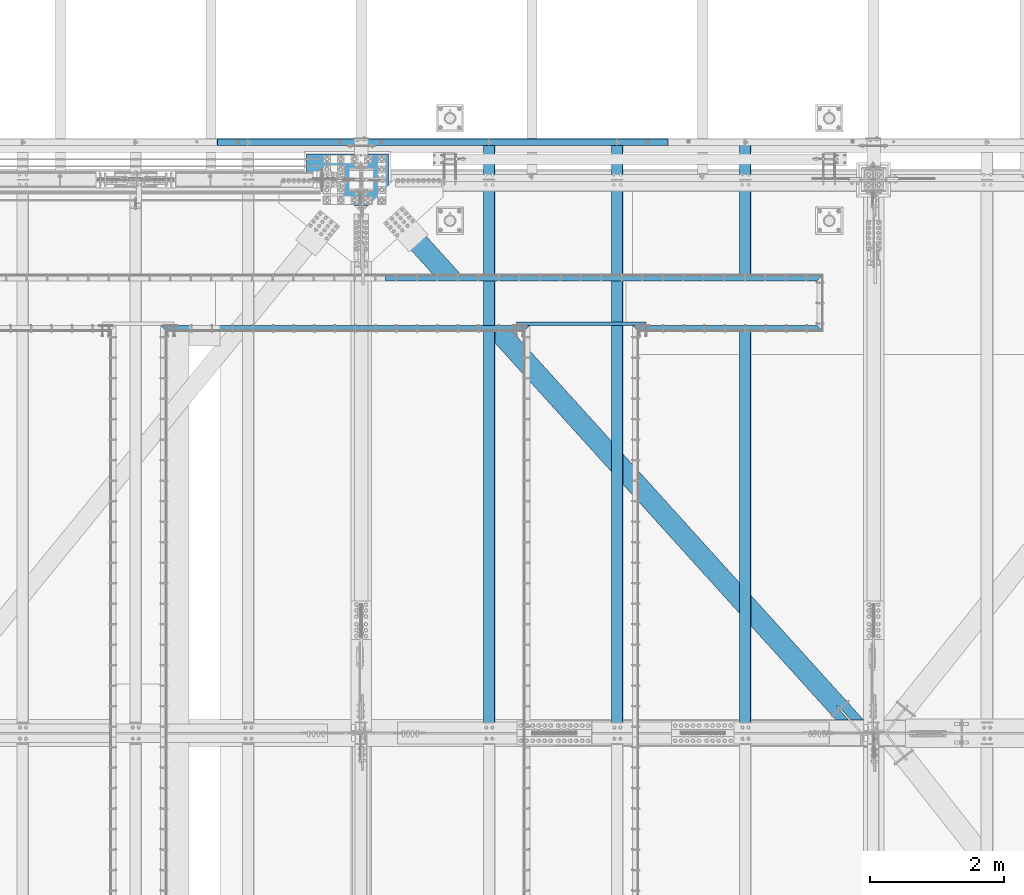
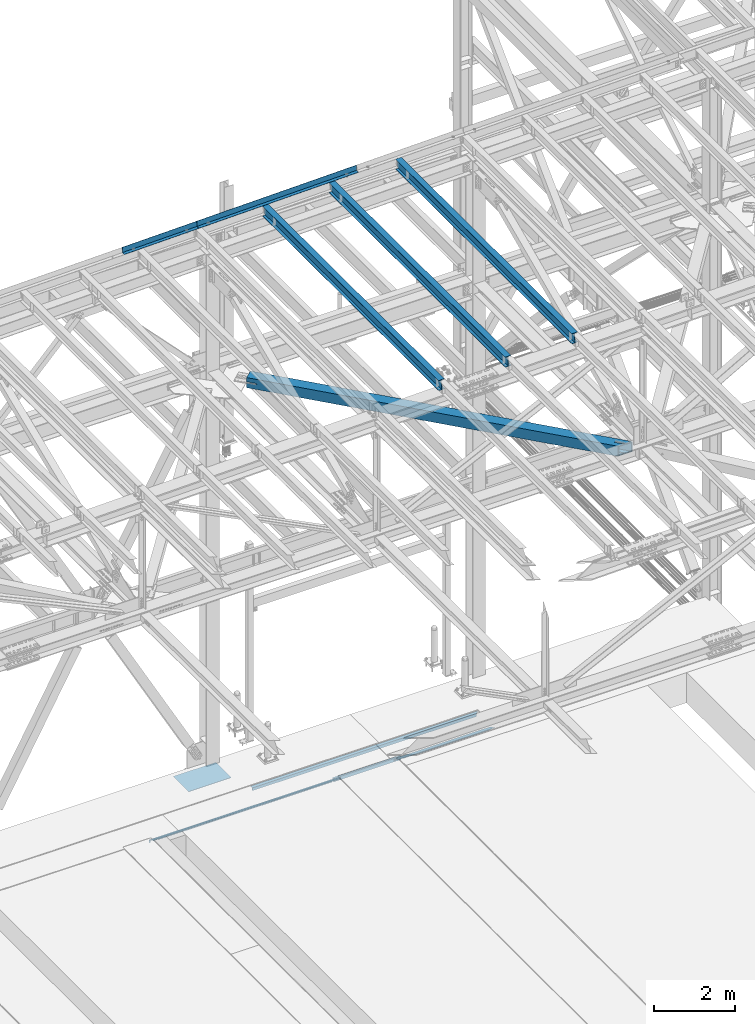
# One storey, part 1927 of 3843: 11 beams, 11 elements without a shape of their own.
"""IFC2X3 building model written with IfcOpenShell, lengths in millimetres."""

from ifc_helpers import new_model, si_unit, frame, origin_with_axes, place, context, subcontext, project, spatial, faceted_brep, material, type_object, element, aggregate, save


model = new_model("IFC2X3")

# Units and contexts
model_context = context("Model", 3, precision=1e-05, world=origin_with_axes())
body_context = subcontext(model_context, "Body", "Model", "MODEL_VIEW")
ifc_project = project(units=[si_unit("LENGTHUNIT", "METRE", prefix="MILLI"), si_unit("AREAUNIT", "SQUARE_METRE"), si_unit("VOLUMEUNIT", "CUBIC_METRE"), si_unit("MASSUNIT", "GRAM", prefix="KILO"), si_unit("TIMEUNIT", "SECOND"), si_unit("PLANEANGLEUNIT", "RADIAN"), si_unit("SOLIDANGLEUNIT", "STERADIAN"), si_unit("THERMODYNAMICTEMPERATUREUNIT", "DEGREE_CELSIUS"), si_unit("LUMINOUSINTENSITYUNIT", "LUMEN")], contexts=[model_context])

# Site, building, storey
site_placement = place(None, origin_with_axes())
site = spatial("IfcSite", under=ifc_project, at=site_placement, CompositionType="ELEMENT")
building_placement = place(site_placement, origin_with_axes())
building = spatial("IfcBuilding", under=site, at=building_placement, Name="Undefined", CompositionType="ELEMENT")
storey_placement = place(building_placement, origin_with_axes())
storey = spatial("IfcBuildingStorey", under=building, at=storey_placement, Name="Undefined", CompositionType="ELEMENT", Elevation=0.0)

# Assembly, beam
assembly_1_placement = place(storey_placement, origin_with_axes())
assembly_1 = element("IfcElementAssembly", 1, at=assembly_1_placement, inside=storey, Name="EMBED_ANGLE", AssemblyPlace="NOTDEFINED", PredefinedType="RIGID_FRAME")
ifc_material_1 = material(Name="STEEL/A36")
beam_type_1 = type_object("IfcBeamType", Name="L3-1/2X3-1/2X5/16", PredefinedType="NOTDEFINED")
beam_1_placement = place(assembly_1_placement, frame((66669.4120093833, 90004.7724002759, 30410.15), z_axis=(0.0, -1.0, 0.0), x_axis=(1.0, 0.0, 0.0)))
beam_1 = element("IfcBeam", 2, at=beam_1_placement, type_object=beam_type_1, material=ifc_material_1, Name="EMBED_ANGLE", ObjectType="L3-1/2X3-1/2X5/16", context=body_context, shape_type="Brep", body=[
    faceted_brep([(44.4499983150599, -44.4500000000007, -36.5125000001281), (44.4499999898835, -44.4500000000007, -44.4500000001281), (44.4499999898835, 36.5125000000044, -44.4500000001281), (44.4499983150599, 36.5125000000007, -36.5125000001281), (260.349999989907, 36.5125000000044, -44.4500000007247), (260.349998315098, 36.5125000000007, -36.5125000007247), (260.349998315098, -44.4499999999971, -36.5125000007247), (260.349999989907, -44.4500000000007, -44.4500000007247), (2743.19996850427, -44.4500000000007, -44.4500000076223), (2751.13746728744, -44.4500000000007, -36.5125000076368), (3.63797880709171e-12, -44.4499999999971, -44.4500000000007), (-3.63797880709171e-12, 44.4499999999971, -44.4500000000007), (2743.19996850427, 44.4500000000007, -44.4500000076223), (7.93749960740388, -44.4500000000007, -36.5124999999825), (7.93749960740388, 36.5125000000007, -36.5124999999825), (44.4499906109268, 36.5125000000007, -2.28901626542211e-08), (88.8999958229251, 36.5125000000007, 44.4500000001353), (88.8999999965163, 44.4499999999971, 44.4500000000007), (260.349981232008, 36.5125000000007, 44.4499999992695), (2832.09995487571, 36.5125000000007, 44.4499999921391), (2832.09995487571, 44.4500000000007, 44.4499999921391), (2751.13746728744, 36.5125000000007, -36.5125000076368)], [[[0, 1, 2, 3]], [[3, 2, 4, 5]], [[6, 5, 4, 7]], [[8, 9, 6, 7]], [[2, 1, 10, 11, 12, 8, 7, 4]], [[13, 10, 1, 0]], [[14, 13, 0, 3]], [[10, 13, 14, 15, 16, 17, 11]], [[17, 16, 18, 19, 20]], [[11, 17, 20, 12]], [[19, 21, 9, 8, 12, 20]], [[18, 16, 15, 14, 3, 5, 21, 19]], [[9, 21, 5, 6]]]),
])
aggregate(assembly_1, [beam_1])

assembly_2_placement = place(storey_placement, origin_with_axes())
assembly_2 = element("IfcElementAssembly", 3, at=assembly_2_placement, inside=storey, Name="EMBED_ANGLE", AssemblyPlace="NOTDEFINED", PredefinedType="RIGID_FRAME")
beam_2_placement = place(assembly_2_placement, frame((59652.6620031643, 90004.7723125, 30410.15), z_axis=(0.0, -1.0, 0.0), x_axis=(1.0, 0.0, 0.0)))
beam_2 = element("IfcBeam", 4, at=beam_2_placement, type_object=beam_type_1, material=ifc_material_1, Name="EMBED_ANGLE", ObjectType="L3-1/2X3-1/2X5/16", context=body_context, shape_type="Brep", body=[
    faceted_brep([(44.4499983150599, -44.4500000000007, -36.5125000001281), (44.4499999898835, -44.4500000000007, -44.4500000001281), (44.4499999898835, 36.5125000000044, -44.4500000001281), (44.4499983150599, 36.5125000000007, -36.5125000001281), (260.349999989907, 36.5125000000044, -44.4500000007247), (260.349998315098, 36.5125000000007, -36.5125000007247), (260.349998315098, -44.4499999999971, -36.5125000007247), (260.349999989907, -44.4500000000007, -44.4500000007247), (5492.75009508596, -44.4500000000007, -44.4499999933905), (5484.81267681251, -44.4500000000007, -36.5124999933905), (5448.32660764583, -44.4499999999971, -36.5124999934487), (5448.32660820939, -44.4500000000007, -44.4499999934487), (5484.81267681251, 36.5125000000007, -36.5124999933905), (5448.32660764583, 36.5125000000007, -36.5124999934487), (5448.32660820939, 36.5125000000044, -44.4499999934487), (5232.42660764582, 36.5125000000007, -36.5124999937107), (5232.42660820938, 36.5125000000044, -44.4499999937107), (5232.42660764582, -44.4500000000007, -36.5124999937107), (5232.42660820938, -44.4500000000007, -44.4499999937107), (3.63797880709171e-12, -44.4499999999971, -44.4500000000007), (-3.63797880709171e-12, 44.4499999999971, -44.4500000000007), (5492.75009508596, 44.4500000000007, -44.4499999933905), (7.93749960740388, -44.4500000000007, -36.5124999999825), (7.93749960740388, 36.5125000000007, -36.5124999999825), (44.4499906109268, 36.5125000000007, -2.28901626542211e-08), (88.8999958229251, 36.5125000000007, 44.4500000001353), (88.8999999965163, 44.4499999999971, 44.4500000000007), (260.349981232008, 36.5125000000007, 44.4499999992695), (5232.42660189748, 36.5125000000007, 44.4500000062981), (5403.85101042334, 36.5125000000007, 44.4500000065018), (5403.85101042334, 44.4500000000007, 44.4500000065018), (5448.32660505529, 36.5125000000007, -0.0260525623307331)], [[[0, 1, 2, 3]], [[3, 2, 4, 5]], [[6, 5, 4, 7]], [[8, 9, 10, 11]], [[9, 12, 13, 10]], [[10, 13, 14, 11]], [[15, 16, 14, 13]], [[17, 18, 16, 15]], [[18, 17, 6, 7]], [[2, 1, 19, 20, 21, 8, 11, 14, 16, 18, 7, 4]], [[22, 19, 1, 0]], [[23, 22, 0, 3]], [[19, 22, 23, 24, 25, 26, 20]], [[26, 25, 27, 28, 29, 30]], [[20, 26, 30, 21]], [[29, 31, 12, 9, 8, 21, 30]], [[28, 27, 25, 24, 23, 3, 5, 15, 13, 12, 31, 29]], [[17, 15, 5, 6]]]),
])
aggregate(assembly_2, [beam_2])

assembly_3_placement = place(storey_placement, origin_with_axes())
assembly_3 = element("IfcElementAssembly", 5, at=assembly_3_placement, inside=storey, Name="EMBED_ANGLE", AssemblyPlace="NOTDEFINED", PredefinedType="RIGID_FRAME")
beam_3_placement = place(assembly_3_placement, frame((62999.1121552795, 90754.0730224609, 30410.15), z_axis=(0.0, 0.0, -1.0), x_axis=(1.0, 0.0, 0.0)))
beam_3 = element("IfcBeam", 6, at=beam_3_placement, type_object=beam_type_1, material=ifc_material_1, Name="EMBED_ANGLE", ObjectType="L3-1/2X3-1/2X5/16", context=body_context, shape_type="Brep", body=[
    faceted_brep([(-3.63797880709171e-12, 44.4499999999971, -44.4500000000007), (-3.63797880709171e-12, 44.4499999999971, 44.4500000000007), (6413.49979789655, 44.4499999999971, 44.4500000000007), (6413.49979789655, 44.4499999999971, -44.4500000000007), (-3.63797880709171e-12, 36.5124999999971, 44.4500000000007), (6421.43729768327, 36.5124999999971, 44.4500000000007), (-3.63797880709171e-12, 36.5124999999971, -36.5125000000007), (6421.43729768327, 36.5124999999971, -36.5125000000007), (3.63797880709171e-12, -44.4499999999971, -36.5125000000007), (6502.39979550779, -44.4499999999971, -36.5125000000007), (3.63797880709171e-12, -44.4499999999971, -44.4500000000007), (6502.39979550779, -44.4499999999971, -44.4500000000007)], [[[0, 1, 2, 3]], [[1, 4, 5, 2]], [[4, 6, 7, 5]], [[6, 8, 9, 7]], [[8, 10, 11, 9]], [[10, 0, 3, 11]], [[5, 7, 9, 11, 3, 2]], [[10, 8, 6, 4, 1, 0]]]),
])
aggregate(assembly_3, [beam_3])

assembly_4_placement = place(storey_placement, origin_with_axes())
assembly_4 = element("IfcElementAssembly", 7, at=assembly_4_placement, inside=storey, Name="BEAM", AssemblyPlace="NOTDEFINED", PredefinedType="RIGID_FRAME")
ifc_material_2 = material(Name="STEEL/A992")
beam_type_2 = type_object("IfcBeamType", Name="W12X26", PredefinedType="NOTDEFINED")
beam_4_placement = place(assembly_4_placement, frame((68348.1092623529, 83985.3697741057, 46261.5127701708), z_axis=(-0.0211520978230692, 0.00173404499923344, 0.999774765557535), x_axis=(0.0, 0.999998495869954, -0.00173443299977423)))
beam_4 = element("IfcBeam", 8, at=beam_4_placement, type_object=beam_type_2, material=ifc_material_2, Name="BEAM", ObjectType="W12X26", context=body_context, shape_type="Brep", body=[
    faceted_brep([(8748.72879077496, -3.17500000096334, -146.049999976822), (8748.72879077496, -82.5500000013853, -146.049999976771), (8748.72879077494, -82.5500000014144, -155.574999976721), (8748.72879077494, 82.549999999479, -155.574999976867), (8748.72879077497, 82.549999999479, -146.049999976894), (8748.72879077496, 3.17499999907159, -146.049999976829), (8748.72879077593, 3.17499999908614, -142.874999284111), (8748.72879077587, -3.17500000094878, -142.874999284119), (8749.69552069856, 3.17499999908614, -138.014919766138), (8749.6955206985, -3.17500000094878, -138.014919766145), (8752.44853459905, 3.17499999910069, -133.894743298035), (8752.448534599, -3.17500000093423, -133.894743298042), (8756.5687110672, 3.17499999911524, -131.141729397561), (8756.56871106714, -3.17500000093423, -131.141729397576), (8761.42879058523, 3.1749999991298, -130.174999474941), (8761.42879058517, -3.17500000091968, -130.174999474948), (8818.5316008915, -3.17500000090513, -130.174999473988), (8818.53183385366, 3.1749999991298, -130.174999474009), (12.1771034262492, 3.17500000049768, 146.049999999559), (12.1800154534576, 82.5500000009197, 146.049999999494), (8748.72879077714, 82.5500000004395, 146.050000022136), (8748.72879077712, 3.17500000001746, 146.050000022202), (12.6969905314618, -82.5500000009342, -155.574999999379), (12.6804737284838, -82.5500000009051, -146.049999999406), (12.6833857556921, -3.17500000048312, -146.049999999472), (12.1768704640854, -3.17499999953725, 146.049999999566), (12.1739584368624, -82.5499999999593, 146.049999999625), (12.1574416338699, -82.5499999999156, 155.57499999959), (12.1634986504796, 82.5500000009488, 155.574999999459), (12.6836187178706, 3.1749999995518, -146.049999999472), (12.6865307450789, 82.5499999999738, -146.049999999545), (12.7030475480569, 82.5499999999447, -155.57499999951), (8748.72879077714, -3.17500000000291, 146.050000022209), (8748.72879077712, -82.5500000004395, 146.050000022275), (8748.72879077714, -82.5500000004104, 155.575000022232), (8748.72879077715, 82.5500000004831, 155.575000022109), (8748.72879077778, -3.17500000001746, 142.875000331573), (8748.72879077785, 3.17500000001746, 142.875000331573), (8749.69552070032, -3.17500000004657, 138.014920813541), (8749.69552070039, 3.17500000000291, 138.014920813555), (8752.4485346008, -3.17500000004657, 133.894744345431), (8752.44853460087, 3.17499999998836, 133.894744345431), (8756.56871106898, -3.17500000006112, 131.141730444993), (8756.56871106903, 3.17499999997381, 131.141730445001), (8761.42879058704, -3.17500000006112, 130.17500052246), (8761.4287905871, 3.17499999995925, 130.175000522468), (8818.08014160984, -3.17500000007567, 130.175000522169), (8818.080374572, 3.17499999995925, 130.175000522147), (8818.50217237184, 3.17499999917345, -113.06965441037), (8818.1023016062, 3.17499999993015, 117.529998893144)], [[[0, 1, 2, 3, 4, 5, 6, 7]], [[7, 6, 8, 9]], [[9, 8, 10, 11]], [[11, 10, 12, 13]], [[13, 12, 14, 15]], [[16, 15, 14, 17]], [[18, 19, 20, 21]], [[22, 23, 24, 25, 26, 27, 28, 19, 18, 29, 30, 31]], [[26, 25, 32, 33]], [[27, 26, 33, 34]], [[28, 27, 34, 35]], [[19, 28, 35, 20]], [[34, 33, 32, 36, 37, 21, 20, 35]], [[38, 39, 37, 36]], [[40, 41, 39, 38]], [[42, 43, 41, 40]], [[44, 45, 43, 42]], [[46, 47, 45, 44]], [[48, 49, 47, 46, 16, 17]], [[12, 10, 8, 6, 5, 29, 18, 21, 37, 39, 41, 43, 45, 47, 49, 48, 17, 14]], [[30, 29, 5, 4]], [[31, 30, 4, 3]], [[22, 31, 3, 2]], [[23, 22, 2, 1]], [[24, 23, 1, 0]], [[46, 44, 42, 40, 38, 36, 32, 25, 24, 0, 7, 9, 11, 13, 15, 16]]]),
])
aggregate(assembly_4, [beam_4])

assembly_5_placement = place(storey_placement, origin_with_axes())
assembly_5 = element("IfcElementAssembly", 9, at=assembly_5_placement, inside=storey, Name="BEAM", AssemblyPlace="NOTDEFINED", PredefinedType="RIGID_FRAME")
beam_5_placement = place(assembly_5_placement, frame((66443.1092623547, 83985.3536007035, 46220.2899105795), z_axis=(-0.0211520981216017, 0.00163008600074681, 0.999774940456443), x_axis=(0.0, 0.999998670813885, -0.0016304509996966)))
beam_5 = element("IfcBeam", 10, at=beam_5_placement, type_object=beam_type_2, material=ifc_material_2, Name="BEAM", ObjectType="W12X26", context=body_context, shape_type="Brep", body=[
    faceted_brep([(8748.72706631446, -3.17499999993015, -146.049999994393), (8748.72706631444, -82.5500000003958, -146.049999994451), (8748.72706631443, -82.5500000003667, -155.574999994453), (8748.72706631443, 82.5500000005559, -155.574999994329), (8748.72706631444, 82.5500000005559, -146.049999994335), (8748.72706631446, 3.17500000010477, -146.0499999944), (8748.72706631488, 3.17500000009022, -142.874999685875), (8748.72706631485, -3.1749999999447, -142.874999685875), (8749.69379623749, 3.17500000009022, -138.014920167851), (8749.69379623746, -3.1749999999447, -138.014920167858), (8752.44681013798, 3.17500000007567, -133.894743699726), (8752.44681013795, -3.1749999999447, -133.894743699719), (8756.56698660612, 3.17500000009022, -131.141729799252), (8756.56698660609, -3.17499999995925, -131.141729799252), (8761.42706612416, 3.17500000006112, -130.174999876654), (8761.42706612412, -3.17499999995925, -130.174999876654), (8818.53270568818, -3.1749999999447, -130.174999876013), (8818.53292468385, 3.17500000007567, -130.174999876006), (12.2084509295964, 3.17499999982829, 146.049999999857), (12.2111883754842, 82.5500000002648, 146.049999999923), (8748.72706631539, 82.5500000001339, 146.050000005358), (8748.72706631539, 3.17499999971187, 146.050000005307), (12.6971698964771, -82.5500000002503, -155.574999999881), (12.6816433046333, -82.5500000002648, -146.049999999894), (12.6843807505211, -3.17499999981374, -146.049999999836), (12.2082319339243, -3.17500000022119, 146.04999999985), (12.2054944880074, -82.5500000006723, 146.049999999799), (12.189967896149, -82.5500000006723, 155.574999999786), (12.1956617836549, 82.5500000002503, 155.57499999991), (12.6845997461933, 3.17500000022119, -146.049999999836), (12.6873371921101, 82.5500000006577, -146.04999999977), (12.7028637839539, 82.5500000006723, -155.574999999757), (8748.72706631539, -3.1750000003376, 146.050000005293), (8748.7270663154, -82.5500000007887, 146.050000005234), (8748.7270663154, -82.5500000007887, 155.575000005221), (8748.7270663154, 82.5500000001339, 155.575000005345), (8748.7270663157, -3.1750000003376, 142.874999931752), (8748.72706631574, 3.17499999969732, 142.874999931752), (8749.69379623829, -3.1750000003085, 138.014920413712), (8749.69379623831, 3.17499999971187, 138.014920413705), (8752.44681013876, -3.17500000032305, 133.894743945573), (8752.44681013878, 3.17499999971187, 133.894743945573), (8756.56698660689, -3.1750000003085, 131.141730045107), (8756.56698660692, 3.17499999971187, 131.141730045099), (8761.42706612496, -3.1750000003085, 130.175000122537), (8761.42706612499, 3.17499999972642, 130.175000122537), (8818.10831217772, -3.1750000003085, 130.175000122683), (8818.10853117339, 3.17499999972642, 130.17500012269), (8818.50504689425, 3.17500000006112, -113.072988786626), (8818.12914901259, 3.17499999974098, 117.526704841053)], [[[0, 1, 2, 3, 4, 5, 6, 7]], [[7, 6, 8, 9]], [[9, 8, 10, 11]], [[11, 10, 12, 13]], [[13, 12, 14, 15]], [[16, 15, 14, 17]], [[18, 19, 20, 21]], [[22, 23, 24, 25, 26, 27, 28, 19, 18, 29, 30, 31]], [[26, 25, 32, 33]], [[27, 26, 33, 34]], [[28, 27, 34, 35]], [[19, 28, 35, 20]], [[34, 33, 32, 36, 37, 21, 20, 35]], [[38, 39, 37, 36]], [[40, 41, 39, 38]], [[42, 43, 41, 40]], [[44, 45, 43, 42]], [[46, 47, 45, 44]], [[48, 49, 47, 46, 16, 17]], [[12, 10, 8, 6, 5, 29, 18, 21, 37, 39, 41, 43, 45, 47, 49, 48, 17, 14]], [[30, 29, 5, 4]], [[31, 30, 4, 3]], [[22, 31, 3, 2]], [[23, 22, 2, 1]], [[24, 23, 1, 0]], [[46, 44, 42, 40, 38, 36, 32, 25, 24, 0, 7, 9, 11, 13, 15, 16]]]),
])
aggregate(assembly_5, [beam_5])

assembly_6_placement = place(storey_placement, origin_with_axes())
assembly_6 = element("IfcElementAssembly", 11, at=assembly_6_placement, inside=storey, Name="BEAM", AssemblyPlace="NOTDEFINED", PredefinedType="RIGID_FRAME")
beam_6_placement = place(assembly_6_placement, frame((64538.1092623537, 83985.3374272494, 46179.0670468877), z_axis=(-0.0211520976508109, 0.00152612699933525, 0.999775104561697), x_axis=(0.0, 0.999998834945517, -0.00152646899991685)))
beam_6 = element("IfcBeam", 12, at=beam_6_placement, type_object=beam_type_2, material=ifc_material_2, Name="BEAM", ObjectType="W12X26", context=body_context, shape_type="Brep", body=[
    faceted_brep([(8748.72543731659, -3.17500000027212, -146.050000008923), (8748.72543731661, -82.550000000112, -146.05000000869), (8748.72543731661, -82.5500000001557, -155.575000008677), (8748.72543731661, 82.54999999953, -155.57500000915), (8748.72543731662, 82.5499999995591, -146.050000009178), (8748.72543731661, 3.17499999971187, -146.050000008938), (8748.72543731653, 3.17499999971915, -142.874999987216), (8748.72543731652, -3.17500000025757, -142.874999987202), (8749.6921672391, 3.17499999974098, -138.014920469192), (8749.6921672391, -3.17500000024302, -138.014920469177), (8752.44518113957, 3.17499999974825, -133.89474400106), (8752.44518113957, -3.17500000023574, -133.894744001045), (8756.56535760773, 3.1749999997628, -131.1417301006), (8756.56535760772, -3.17500000022847, -131.141730100586), (8761.42543712576, 3.1749999997628, -130.175000178031), (8761.42543712576, -3.17500000022119, -130.175000178016), (8818.53390588889, -3.17500000021391, -130.175000178409), (8818.53411091806, 3.17499999977008, -130.175000178431), (12.2397986061551, 3.17500000045402, 146.049999999756), (12.2423614708387, 82.5500000003012, 146.049999999523), (8748.72543731629, 82.5500000004977, 146.049999990362), (8748.72543731627, 3.17500000065047, 146.049999990588), (12.6973016678676, -82.5500000001412, -155.575000000448), (12.6828130694339, -82.5500000003158, -146.04999999953), (12.6853759341175, -3.1750000004613, -146.049999999763), (12.2395935769746, -3.1749999995227, 146.04999999977), (12.237030712291, -82.5499999993699, 146.050000000003), (12.2224943310721, -82.5499999993408, 155.57499999999), (12.2278250896197, 82.5500000003449, 155.57499999951), (12.685580963298, 3.17499999951542, -146.049999999777), (12.6881438279815, 82.5499999993626, -146.050000000003), (12.7027290292899, 82.5499999995591, -155.575000000557), (8748.72543731626, -3.17499999933352, 146.04999999061), (8748.72543731627, -82.5499999991807, 146.049999990842), (8748.72543731627, -82.5499999991516, 155.574999990822), (8748.72543731627, 82.5500000005341, 155.574999990349), (8748.72543731624, -3.1749999993408, 142.874999629959), (8748.72543731623, 3.17500000064319, 142.87499962993), (8749.69216723884, -3.17499999936263, 138.014920111935), (8749.69216723883, 3.17500000062137, 138.01492011192), (8752.44518113932, -3.1749999993699, 133.894743643803), (8752.44518113931, 3.17500000061409, 133.894743643788), (8756.56535760744, -3.17499999937718, 131.141729743329), (8756.56535760745, 3.17500000060681, 131.141729743322), (8761.42543712546, -3.17499999938445, 130.174999820738), (8761.42543712546, 3.17500000059954, 130.174999820716), (8818.13657813579, -3.17499999938445, 130.174999820621), (8818.13678316497, 3.17500000060681, 130.1749998206), (8818.5080161237, 3.17499999982829, -113.076321161774), (8818.15609112593, 3.17500000056316, 117.52341029713)], [[[0, 1, 2, 3, 4, 5, 6, 7]], [[7, 6, 8, 9]], [[9, 8, 10, 11]], [[11, 10, 12, 13]], [[13, 12, 14, 15]], [[16, 15, 14, 17]], [[18, 19, 20, 21]], [[22, 23, 24, 25, 26, 27, 28, 19, 18, 29, 30, 31]], [[26, 25, 32, 33]], [[27, 26, 33, 34]], [[28, 27, 34, 35]], [[19, 28, 35, 20]], [[34, 33, 32, 36, 37, 21, 20, 35]], [[38, 39, 37, 36]], [[40, 41, 39, 38]], [[42, 43, 41, 40]], [[44, 45, 43, 42]], [[46, 47, 45, 44]], [[48, 49, 47, 46, 16, 17]], [[12, 10, 8, 6, 5, 29, 18, 21, 37, 39, 41, 43, 45, 47, 49, 48, 17, 14]], [[30, 29, 5, 4]], [[31, 30, 4, 3]], [[22, 31, 3, 2]], [[23, 22, 2, 1]], [[24, 23, 1, 0]], [[46, 44, 42, 40, 38, 36, 32, 25, 24, 0, 7, 9, 11, 13, 15, 16]]]),
])
aggregate(assembly_6, [beam_6])

assembly_7_placement = place(storey_placement, origin_with_axes())
assembly_7 = element("IfcElementAssembly", 13, at=assembly_7_placement, inside=storey, Name="CHANNEL", AssemblyPlace="NOTDEFINED", PredefinedType="RIGID_FRAME")
beam_type_3 = type_object("IfcBeamType", PredefinedType="NOTDEFINED")
beam_7_placement = place(assembly_7_placement, frame((61562.4836072744, 92722.6999790447, 46261.4051616488), z_axis=(0.999776270257024, 0.0, 0.0211520550054619), x_axis=(0.0, 1.0, 0.0)))
beam_7 = element("IfcBeam", 14, at=beam_7_placement, type_object=beam_type_3, material=ifc_material_1, Name="BENT_PLATE", context=body_context, shape_type="Brep", body=[
    faceted_brep([(8.44011083245277e-10, 1.59125193022192e-08, -1067.59399999826), (-6.25732354819775e-10, 3.17499999893334, -1064.41900002186), (95.2499985611794, 3.17500004360772, -1064.41900002224), (98.4249043767195, 6.20711944065988e-08, -1067.59399999864), (95.2499984961323, 161.925001494244, -1064.41899820814), (98.4249043103628, 161.925001495598, -1067.59399999904), (95.2499985624891, 3.1750000457323, 1064.33229318664), (95.2499984943133, 161.925001499403, 1064.3322951488), (98.4243330560712, 0.000710580759914592, 1067.43942493089), (-2.3283064365387e-09, 3.1750000010652, 1064.33229317961), (-8.58562998473644e-10, 0.000710533910023514, 1067.59399999828), (98.4243329892342, 161.925001500771, 1067.59399999752), (101.599998496138, 161.925001496951, -1067.59399999905), (101.599998563848, -3.17499995341495, -1067.59399999865), (2.31375452131033e-09, -3.1750000010652, -1067.59399999826), (101.599998565158, -3.17499995127582, 1067.59399999789), (101.599998494305, 161.925001502124, 1067.59399999749), (6.11180439591408e-10, -3.17499999892607, 1067.59399999828)], [[[0, 1, 2, 3]], [[3, 2, 4, 5]], [[6, 7, 4, 2]], [[8, 6, 9, 10]], [[11, 7, 6, 8]], [[12, 13, 14, 0, 3, 5]], [[15, 13, 12, 16]], [[17, 14, 13, 15]], [[14, 17, 10, 9, 1, 0]], [[9, 6, 2, 1]], [[7, 11, 16, 12, 5, 4]], [[17, 15, 16, 11, 8, 10]]]),
])
aggregate(assembly_7, [beam_7])

assembly_8_placement = place(storey_placement, origin_with_axes())
assembly_8 = element("IfcElementAssembly", 15, at=assembly_8_placement, inside=storey, Name="CHANNEL", AssemblyPlace="NOTDEFINED", PredefinedType="RIGID_FRAME")
beam_8_placement = place(assembly_8_placement, frame((64915.239907877, 92722.6999533716, 46332.3388617484), z_axis=(0.999776270257024, 0.0, 0.0211520550054619), x_axis=(0.0, 1.0, 0.0)))
beam_8 = element("IfcBeam", 16, at=beam_8_placement, type_object=beam_type_3, material=ifc_material_1, Name="BENT_PLATE", context=body_context, shape_type="Brep", body=[
    faceted_brep([(5.82076609134674e-11, -3.17499999999563, -2286.0), (5.82076609134674e-11, -3.17499999999563, 2286.0), (-4.36557456851006e-11, 3.17499999998836, 2286.0), (-4.36557456851006e-11, 3.17499999998836, -2286.0), (95.2499986633193, 3.17500004695466, 2285.99999999594), (95.2499986602343, 3.17500004237081, -2285.99999999666), (101.599998662903, -3.17499995464459, -2285.99999999667), (101.600001545667, -3.17499906016019, 2285.99999999734), (95.2499985934701, 161.925001402509, 2285.99999999556), (95.2499985968607, 161.925001391297, -2285.99999999705), (101.599998593476, 161.925001405216, 2285.99999999553), (101.599998596852, 161.925001394004, -2285.99999999707)], [[[0, 1, 2, 3]], [[3, 2, 4, 5]], [[1, 0, 6, 7]], [[5, 4, 8, 9]], [[4, 2, 1, 7, 10, 8]], [[7, 6, 11, 10]], [[6, 0, 3, 5, 9, 11]], [[10, 11, 9, 8]]]),
])
aggregate(assembly_8, [beam_8])

assembly_9_placement = place(storey_placement, origin_with_axes())
assembly_9 = element("IfcElementAssembly", 17, at=assembly_9_placement, inside=storey, AssemblyPlace="NOTDEFINED", PredefinedType="RIGID_FRAME")
ifc_material_3 = material()
beam_type_4 = type_object("IfcBeamType", Name="HSS12X12X3/4", PredefinedType="NOTDEFINED")
beam_9_placement = place(assembly_9_placement, frame((62636.4, 92214.7, 42246.55), z_axis=(0.741698455243905, 0.670733480220575, 0.0), x_axis=(0.670733509108467, -0.741698429119977, 0.0)))
beam_9 = element("IfcBeam", 18, at=beam_9_placement, type_object=beam_type_4, material=ifc_material_3, ObjectType="HSS12X12X3/4", context=body_context, shape_type="Brep", body=[
    faceted_brep([(1020.26332782855, 1.58750000000146, 152.40000000209), (1020.26332782846, 1.58750000000146, 133.350000002043), (1272.67582743478, 1.58750000000146, 133.35000000248), (1272.67582743495, 1.58750000000146, 152.400000002526), (1278.14341712062, 0.499928791716229, 133.350000002494), (1278.14341712078, 0.499928791716229, 152.400000002526), (1282.77861584063, -2.59721197552426, 133.350000002509), (1282.77861584078, -2.59721197552426, 152.400000002541), (1285.87575660784, -7.23241069557116, 133.350000002509), (1285.87575660799, -7.23241069557116, 152.400000002541), (1272.67582743495, -26.9874999999956, 152.400000002526), (1272.67582743478, -26.9874999999956, 133.35000000248), (1020.26332782846, -26.9874999999956, 133.350000002043), (1020.26332782855, -26.9874999999956, 152.40000000209), (1278.14341712078, -25.8999287917104, 152.400000002526), (1278.14341712062, -25.8999287917104, 133.350000002494), (1282.77861584078, -22.8027880244699, 152.400000002541), (1282.77861584063, -22.8027880244699, 133.350000002509), (1285.87575660799, -18.167589304423, 152.400000002541), (1285.87575660784, -18.167589304423, 133.350000002509), (1286.96332781626, -12.6999996185259, 152.400000002541), (1286.96332781612, -12.6999996185259, 133.350000002509), (1020.26332782715, 1.58750000000146, -133.349999998463), (1020.26332782706, 1.58750000000146, -152.399999998481), (1272.6758274325, 1.58750000000146, -152.399999998044), (1272.67582743265, 1.58750000000146, -133.349999998012), (1278.14341711835, 0.499928791716229, -152.39999999803), (1278.14341711849, 0.499928791716229, -133.349999997998), (1282.77861583833, -2.59721197552426, -152.399999998015), (1282.7786158385, -2.59721197552426, -133.349999997998), (1285.87575660555, -7.23241069557116, -152.399999998015), (1285.8757566057, -7.23241069557116, -133.349999997983), (1272.67582743265, -26.9874999999956, -133.349999998012), (1272.6758274325, -26.9874999999956, -152.399999998044), (1020.26332782706, -26.9874999999956, -152.399999998481), (1020.26332782715, -26.9874999999956, -133.349999998463), (1278.14341711849, -25.8999287917104, -133.349999997998), (1278.14341711835, -25.8999287917104, -152.39999999803), (1282.7786158385, -22.8027880244699, -133.349999997998), (1282.77861583833, -22.8027880244699, -152.399999998015), (1285.8757566057, -18.167589304423, -133.349999997983), (1285.87575660555, -18.167589304423, -152.399999998015), (1286.96332781396, -12.6999996185259, -133.349999997983), (1286.96332781382, -12.6999996185259, -152.399999998015), (10562.7366202554, 152.400000000001, -14.2874939009052), (10562.7366202554, 133.349999999999, -14.2874939009052), (10815.1491198144, 133.349999999999, -14.2874928335914), (10815.1491198144, 152.400000000001, -14.2874928335914), (10557.2690305541, 152.400000000001, -13.1999227112901), (10557.2690305541, 133.349999999999, -13.1999227112901), (10552.6338318152, 152.400000000001, -10.1027819516094), (10552.6338318152, 133.349999999999, -10.1027819516094), (10549.5366910314, 152.400000000001, -5.46758322883397), (10549.5366910314, 133.349999999999, -5.46758322883397), (10548.4491198133, 152.400000000001, 6.46679836791009e-06), (10548.4491198133, 133.349999999999, 6.46679836791009e-06), (10549.5366910119, 152.400000000001, 5.46759537104663), (10549.5366910119, 133.349999999999, 5.46759537104663), (10552.6338317626, 152.400000000001, 10.102794088365), (10552.6338317626, 133.349999999999, 10.102794088365), (10557.2690304638, 152.400000000001, 13.1999348631907), (10557.2690304638, 133.349999999999, 13.1999348631907), (10562.7366201344, 152.400000000001, 14.2875060901388), (10562.7366201344, 133.349999999999, 14.2875060901388), (10840.9900921176, 152.400000000001, 14.2875072673232), (10840.9900921176, 133.349999999999, 14.2875072673232), (1020.26334108711, 133.349999999999, 133.350000000395), (1020.26334108776, 133.349999999999, -133.349999999384), (10707.4783957891, 133.349999999999, -133.349999994531), (10948.6608031, 133.349999999999, 133.350000005375), (10557.2690304638, -152.400000000001, 13.1999348631907), (10557.2690304638, -133.349999999999, 13.1999348631907), (10562.7366201344, -133.349999999999, 14.2875060901388), (10562.7366201344, -152.400000000001, 14.2875060901388), (10552.6338317626, -152.400000000001, 10.102794088365), (10552.6338317626, -133.349999999999, 10.102794088365), (10549.5366910119, -152.400000000001, 5.46759537104663), (10549.5366910119, -133.349999999999, 5.46759537104663), (10548.4491198133, -152.400000000001, 6.46679836791009e-06), (10548.4491198133, -133.349999999999, 6.46679836791009e-06), (10549.5366910314, -152.400000000001, -5.46758322883397), (10549.5366910314, -133.349999999999, -5.46758322883397), (10552.6338318152, -152.400000000001, -10.1027819516094), (10552.6338318152, -133.349999999999, -10.1027819516094), (10557.2690305541, -152.400000000001, -13.1999227112901), (10557.2690305541, -133.349999999999, -13.1999227112901), (10562.7366202554, -152.400000000001, -14.2874939009052), (10562.7366202554, -133.349999999999, -14.2874939009052), (10815.1491198144, -152.400000000001, -14.2874928335914), (10815.1491198144, -133.349999999999, -14.2874928335914), (10690.2510809812, 152.400000000001, -152.39999999453), (10707.4783957891, -133.349999999999, -133.349999994531), (10690.2510809812, -152.400000000001, -152.39999999453), (1020.26334108781, 152.400000000001, -152.399999999372), (1020.26334108781, -152.400000000001, -152.399999999372), (1020.26334108711, -133.349999999999, 133.350000000395), (1020.26334108776, -133.349999999999, -133.349999999384), (1020.26334108706, -152.400000000001, 152.400000000383), (10948.6608031, -133.349999999999, 133.350000005375), (10840.9900921176, -133.349999999999, 14.2875072673232), (10840.9900921176, -152.400000000001, 14.2875072673232), (10965.8881179079, -152.400000000001, 152.400000005371), (10965.8881179079, 152.400000000001, 152.400000005371), (1020.26334108706, 152.400000000001, 152.400000000383)], [[[0, 1, 2, 3]], [[3, 2, 4, 5]], [[5, 4, 6, 7]], [[7, 6, 8, 9]], [[10, 11, 12, 13]], [[14, 15, 11, 10]], [[16, 17, 15, 14]], [[18, 19, 17, 16]], [[20, 21, 19, 18]], [[9, 8, 21, 20]], [[22, 23, 24, 25]], [[25, 24, 26, 27]], [[27, 26, 28, 29]], [[29, 28, 30, 31]], [[32, 33, 34, 35]], [[36, 37, 33, 32]], [[38, 39, 37, 36]], [[40, 41, 39, 38]], [[42, 43, 41, 40]], [[31, 30, 43, 42]], [[44, 45, 46, 47]], [[45, 44, 48, 49]], [[49, 48, 50, 51]], [[51, 50, 52, 53]], [[53, 52, 54, 55]], [[55, 54, 56, 57]], [[57, 56, 58, 59]], [[59, 58, 60, 61]], [[61, 60, 62, 63]], [[63, 62, 64, 65]], [[66, 67, 68, 46, 45, 49, 51, 53, 55, 57, 59, 61, 63, 65, 69]], [[70, 71, 72, 73]], [[74, 75, 71, 70]], [[76, 77, 75, 74]], [[78, 79, 77, 76]], [[80, 81, 79, 78]], [[82, 83, 81, 80]], [[84, 85, 83, 82]], [[86, 87, 85, 84]], [[87, 86, 88, 89]], [[90, 47, 46, 68, 91, 89, 88, 92]], [[28, 26, 24, 23, 93, 90, 92, 94, 34, 33, 37, 39, 41, 43, 30]], [[95, 96, 35, 34, 94, 97, 13, 12]], [[6, 4, 2, 1, 66, 69, 98, 95, 12, 11, 15, 17, 19, 21, 8]], [[72, 71, 75, 77, 79, 81, 83, 85, 87, 89, 91, 96, 95, 98, 99]], [[73, 72, 99, 100]], [[97, 94, 92, 88, 86, 84, 82, 80, 78, 76, 74, 70, 73, 100, 101]], [[99, 98, 69, 65, 64, 102, 101, 100]], [[62, 60, 58, 56, 54, 52, 50, 48, 44, 47, 90, 93, 103, 102, 64]], [[16, 14, 10, 13, 97, 101, 102, 103, 0, 3, 5, 7, 9, 20, 18]], [[103, 93, 23, 22, 67, 66, 1, 0]], [[38, 36, 32, 35, 96, 91, 68, 67, 22, 25, 27, 29, 31, 42, 40]]]),
])
aggregate(assembly_9, [beam_9])

assembly_10_placement = place(storey_placement, origin_with_axes())
assembly_10 = element("IfcElementAssembly", 19, at=assembly_10_placement, inside=storey, Name="COVER PLATE", AssemblyPlace="NOTDEFINED", PredefinedType="RIGID_FRAME")
beam_type_5 = type_object("IfcBeamType", PredefinedType="NOTDEFINED")
beam_10_placement = place(assembly_10_placement, frame((64942.2115744054, 90074.6231429596, 30403.8), z_axis=(0.0, 0.0, 1.0), x_axis=(1.0, 0.0, 0.0)))
beam_10 = element("IfcBeam", 20, at=beam_10_placement, type_object=beam_type_5, material=ifc_material_1, Name="COVER PLATE", context=body_context, shape_type="Brep", body=[
    faceted_brep([(6.54836185276508e-11, 25.4000000000087, -50.7999999999993), (6.54836185276508e-11, 25.4000000000087, 50.7999999999993), (1930.40032324089, 25.4000000105443, 50.7999999999993), (1930.40032324089, 25.4000000105443, -50.7999999999993), (-2.91038304567337e-11, -25.3999999999942, 50.7999999999993), (1930.40032324079, -25.3999999894731, 50.7999999999993), (-2.91038304567337e-11, -25.3999999999942, -50.7999999999993), (1930.40032324079, -25.3999999894731, -50.7999999999993)], [[[0, 1, 2, 3]], [[1, 4, 5, 2]], [[4, 6, 7, 5]], [[6, 0, 3, 7]], [[5, 7, 3, 2]], [[6, 4, 1, 0]]]),
])
aggregate(assembly_10, [beam_10])

assembly_11_placement = place(storey_placement, origin_with_axes())
assembly_11 = element("IfcElementAssembly", 21, at=assembly_11_placement, inside=storey, Name="TEMPLATE", AssemblyPlace="NOTDEFINED", PredefinedType="RIGID_FRAME")
ifc_material_4 = material(Name="STEEL/A572-50")
beam_type_6 = type_object("IfcBeamType", PredefinedType="NOTDEFINED")
beam_11_placement = place(assembly_11_placement, frame((62433.2, 91833.7000030518, 30065.6625), z_axis=(-1.0, 0.0, 0.0), x_axis=(0.0, 1.0, 0.0)))
beam_11 = element("IfcBeam", 22, at=beam_11_placement, type_object=beam_type_6, material=ifc_material_4, Name="TEMPLATE", context=body_context, shape_type="Brep", body=[
    faceted_brep([(0.0, 4.76250000000073, -609.599999999999), (0.0, 4.76250000000073, 609.599999999999), (762.00001220702, 4.76250000000073, 609.599999999999), (762.00001220702, 4.76250000000073, -609.599999999999), (0.0, -4.76250000000073, 609.599999999999), (762.00001220702, -4.76250000000073, 609.599999999999), (0.0, -4.76250000000073, -609.599999999999), (762.00001220702, -4.76250000000073, -609.599999999999)], [[[0, 1, 2, 3]], [[1, 4, 5, 2]], [[4, 6, 7, 5]], [[6, 0, 3, 7]], [[5, 7, 3, 2]], [[6, 4, 1, 0]]]),
])
aggregate(assembly_11, [beam_11])

save(model, "model.ifc")
